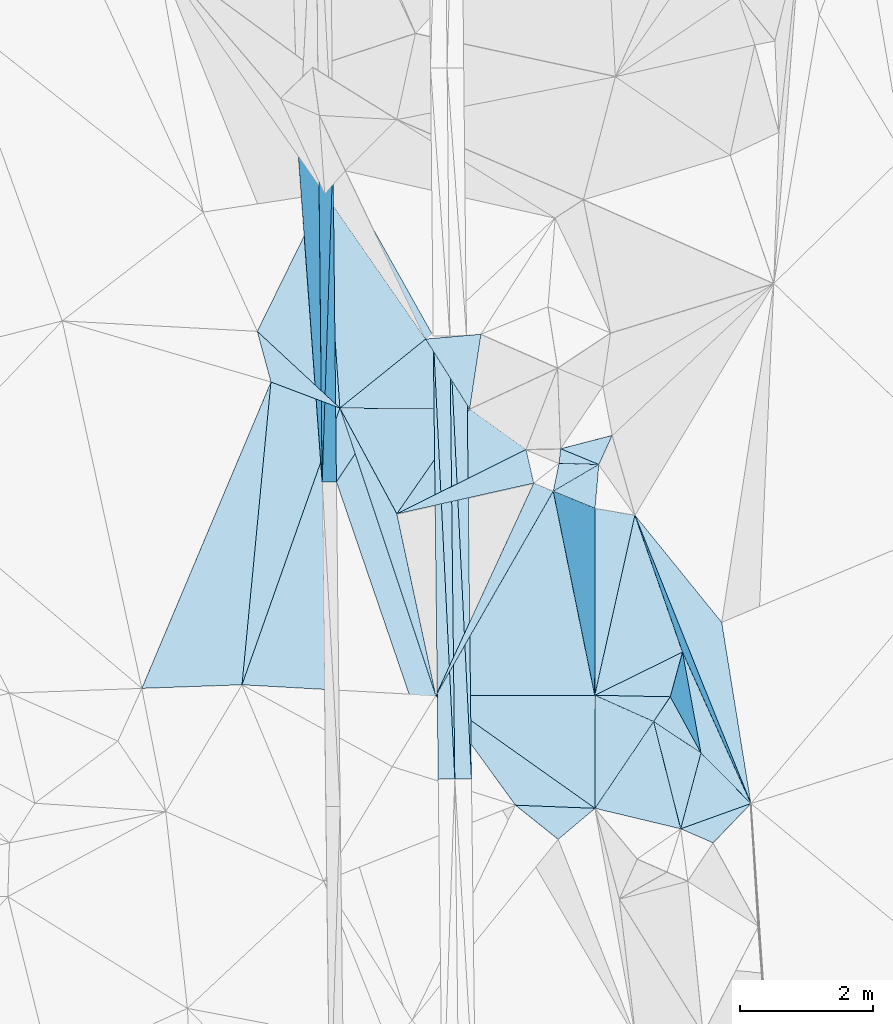
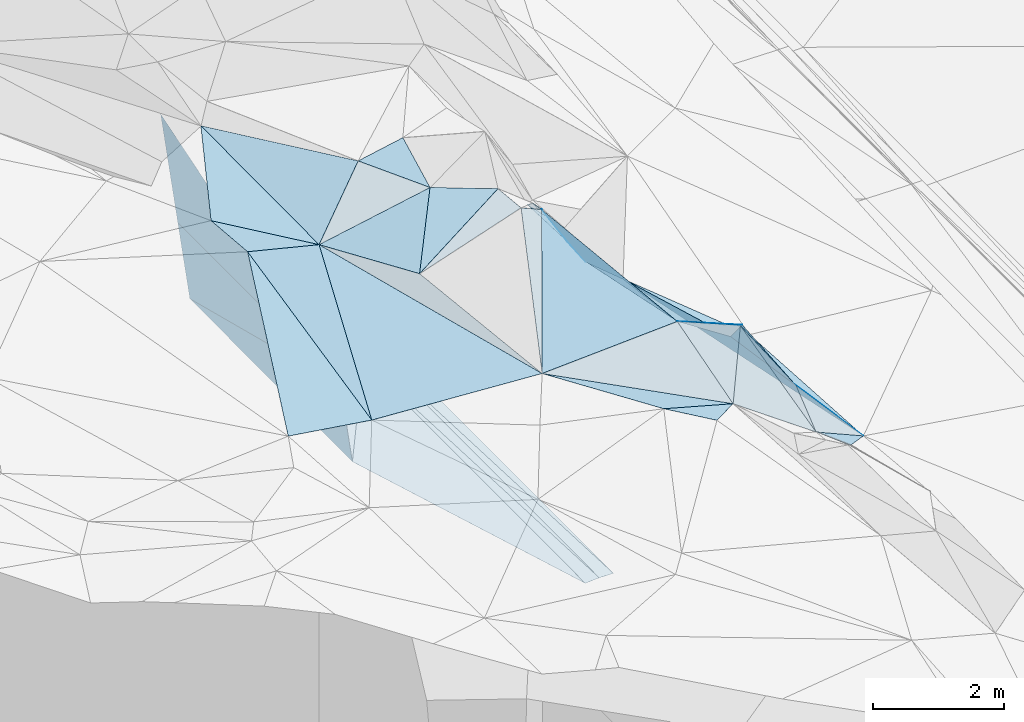
# One storey, part 14 of 275: 45 plates.
"""IFC2X3 building model written with IfcOpenShell, lengths in millimetres."""

from ifc_helpers import new_model, si_unit, frame, origin_with_axes, place, context, subcontext, project, spatial, polyline, outline, extrude, material, type_object, element, save


model = new_model("IFC2X3")

# Units and contexts
model_context = context("Model", 3, precision=1e-05, world=origin_with_axes())
body_context = subcontext(model_context, "Body", "Model", "MODEL_VIEW")
ifc_project = project(units=[si_unit("LENGTHUNIT", "METRE", prefix="MILLI"), si_unit("AREAUNIT", "SQUARE_METRE"), si_unit("VOLUMEUNIT", "CUBIC_METRE"), si_unit("MASSUNIT", "GRAM", prefix="KILO"), si_unit("TIMEUNIT", "SECOND"), si_unit("PLANEANGLEUNIT", "RADIAN"), si_unit("SOLIDANGLEUNIT", "STERADIAN"), si_unit("THERMODYNAMICTEMPERATUREUNIT", "DEGREE_CELSIUS"), si_unit("LUMINOUSINTENSITYUNIT", "LUMEN")], contexts=[model_context])

# Site, building, storey
site_placement = place(None, origin_with_axes())
site = spatial("IfcSite", under=ifc_project, at=site_placement, CompositionType="ELEMENT")
building_placement = place(site_placement, origin_with_axes())
building = spatial("IfcBuilding", under=site, at=building_placement, Name="Undefined", CompositionType="ELEMENT")
storey_placement = place(building_placement, origin_with_axes())
storey = spatial("IfcBuildingStorey", under=building, at=storey_placement, Name="Undefined", CompositionType="ELEMENT", Elevation=0.0)

# Plates
ifc_material = material()
plate_type_1 = type_object("IfcPlateType", PredefinedType="NOTDEFINED")
plate_1_placement = place(storey_placement, frame((-105426.912495277, 16546.9487715069, 43053.8472921868), z_axis=(-0.989920838668954, -0.00755210225404067, -0.141420291756521), x_axis=(0.0319556229056625, 0.960913281916359, -0.274999096001137)))
element("IfcPlate", 1, at=plate_1_placement, inside=storey, type_object=plate_type_1, material=ifc_material, Name="00_PR", context=body_context, shape_type="SweptSolid", body=[
    extrude(outline(polyline([(0.0, 0.0), (5085.87841796875, -9.41508915275335e-09), (421.610626220703, 1455.39086914063), (0.0, 0.0)])), frame((-8.85201319254618e-08, 2.18876761149539e-07, -0.5000001331573), z_axis=(0.0, 0.0, 1.0), x_axis=(1.0, 0.0, 0.0)), (0.0, 0.0, 1.0), 1.0),
])
plate_2_placement = place(storey_placement, frame((-105264.390081203, 21434.0370147272, 41655.2352908371), z_axis=(-0.989920729418167, -0.00755232337685866, -0.14142104468507), x_axis=(-0.0319556228829071, -0.960913281921553, 0.274999095985634)))
element("IfcPlate", 2, at=plate_2_placement, inside=storey, type_object=plate_type_1, material=ifc_material, Name="00_PR", context=body_context, shape_type="SweptSolid", body=[
    extrude(outline(polyline([(0.0, 0.0), (5085.87841796875, -9.41508915275335e-09), (421.443664550781, 1455.43933105469), (0.0, 0.0)])), frame((-8.85201319254618e-08, 2.18876761149539e-07, -0.5000001331573), z_axis=(0.0, 0.0, 1.0), x_axis=(1.0, 0.0, 0.0)), (0.0, 0.0, 1.0), 1.0),
])
plate_type_2 = type_object("IfcPlateType", PredefinedType="NOTDEFINED")
plate_3_placement = place(storey_placement, frame((-103755.768904109, 18743.2154970939, 41598.8007343522), z_axis=(0.0497017362717668, 0.0214177055721637, -0.998534435710455), x_axis=(0.998695835344097, 0.0106236001031736, 0.0499376369805733)))
element("IfcPlate", 3, at=plate_3_placement, inside=storey, type_object=plate_type_2, material=ifc_material, Name="00_PR", context=body_context, shape_type="SweptSolid", body=[
    extrude(outline(polyline([(0.0, 0.0), (250.312210083008, 6.83940015733242e-10), (247.044891357422, 6669.61083984375), (0.0, 0.0)])), frame((-8.85201319254618e-08, 2.18876761149539e-07, -0.5000001331573), z_axis=(0.0, 0.0, 1.0), x_axis=(1.0, 0.0, 0.0)), (0.0, 0.0, 1.0), 1.0),
])
plate_4_placement = place(storey_placement, frame((-103755.768904109, 18743.2154970939, 41598.8007343522), z_axis=(0.0496787260777185, 0.0214166077608199, -0.998535604316298), x_axis=(0.0486362961333859, -0.998635843411922, -0.0189990250114247)))
element("IfcPlate", 4, at=plate_4_placement, inside=storey, type_object=plate_type_2, material=ifc_material, Name="00_PR", context=body_context, shape_type="SweptSolid", body=[
    extrude(outline(polyline([(0.0, 0.0), (6674.1845703125, 1.07684172689915e-08), (6665.19580078125, 250.150833129883), (0.0, 0.0)])), frame((-8.85201319254618e-08, 2.18876761149539e-07, -0.5000001331573), z_axis=(0.0, 0.0, 1.0), x_axis=(1.0, 0.0, 0.0)), (0.0, 0.0, 1.0), 1.0),
])
plate_5_placement = place(storey_placement, frame((-103181.213913095, 12081.0715240582, 41466.9972098134), z_axis=(-0.0202357027179379, 0.0206568841942623, -0.999581817297062), x_axis=(-0.999731085484783, -0.0117437361173947, 0.0199960340423303)))
element("IfcPlate", 5, at=plate_5_placement, inside=storey, type_object=plate_type_2, material=ifc_material, Name="00_PR", context=body_context, shape_type="SweptSolid", body=[
    extrude(outline(polyline([(0.0, 0.0), (250.049530029297, -4.94765117764473e-10), (249.132720947266, 6669.61181640625), (0.0, 0.0)])), frame((-8.85201319254618e-08, 2.18876761149539e-07, -0.5000001331573), z_axis=(0.0, 0.0, 1.0), x_axis=(1.0, 0.0, 0.0)), (0.0, 0.0, 1.0), 1.0),
])
plate_6_placement = place(storey_placement, frame((-103505.818107001, 18745.8743343726, 41611.3002096446), z_axis=(-0.0202125334810141, 0.0206580225063796, -0.999582262545912), x_axis=(0.9997434979277, 0.0106347531180576, -0.0199960090369341)))
element("IfcPlate", 6, at=plate_6_placement, inside=storey, type_object=plate_type_2, material=ifc_material, Name="00_PR", context=body_context, shape_type="SweptSolid", body=[
    extrude(outline(polyline([(0.0, 0.0), (250.049896240234, -1.4915713109076e-09), (256.527893066406, 6669.33154296875), (0.0, 0.0)])), frame((-8.85201319254618e-08, 2.18876761149539e-07, -0.5000001331573), z_axis=(0.0, 0.0, 1.0), x_axis=(1.0, 0.0, 0.0)), (0.0, 0.0, 1.0), 1.0),
])
plate_type_3 = type_object("IfcPlateType", PredefinedType="NOTDEFINED")
plate_7_placement = place(storey_placement, frame((-101839.855637814, 17047.4674480468, 44879.7412121457), z_axis=(-0.804365126994904, -0.291772126949345, -0.51755750251535), x_axis=(0.585574521203103, -0.241977802974004, -0.773659629931426)))
element("IfcPlate", 7, at=plate_7_placement, inside=storey, type_object=plate_type_3, material=ifc_material, Name="00", context=body_context, shape_type="SweptSolid", body=[
    extrude(outline(polyline([(0.0, 0.0), (982.344116210938, 1.28784449771047e-09), (-84.8989639282227, 258.054565429688), (0.0, 0.0)])), frame((-8.85201319254618e-08, 2.18876761149539e-07, -0.5000001331573), z_axis=(0.0, 0.0, 1.0), x_axis=(1.0, 0.0, 0.0)), (0.0, 0.0, 1.0), 1.0),
])
plate_type_4 = type_object("IfcPlateType", PredefinedType="NOTDEFINED")
plate_8_placement = place(storey_placement, frame((-105478.664898104, 21431.8539448154, 43155.2352918256), z_axis=(-0.989920729418167, -0.00755232337685866, -0.14142104468507), x_axis=(0.0105914770758941, -0.999728597747416, -0.020749733958179)))
element("IfcPlate", 8, at=plate_8_placement, inside=storey, type_object=plate_type_4, material=ifc_material, Name="00_PR", context=body_context, shape_type="SweptSolid", body=[
    extrude(outline(polyline([(0.0, 0.0), (4886.2314453125, 6.18456397205591e-10), (-44.4548950195313, 2157.69262695313), (0.0, 0.0)])), frame((-8.85201319254618e-08, 2.18876761149539e-07, -0.5000001331573), z_axis=(0.0, 0.0, 1.0), x_axis=(1.0, 0.0, 0.0)), (0.0, 0.0, 1.0), 1.0),
])
plate_type_5 = type_object("IfcPlateType", PredefinedType="NOTDEFINED")
plate_9_placement = place(storey_placement, frame((-100033.394886136, 11329.9242212821, 43459.6017432081), z_axis=(-0.377068188980827, 0.472665950690349, -0.796496377842804), x_axis=(-0.834528139075674, 0.1996179788847, 0.513532323809202)))
element("IfcPlate", 9, at=plate_9_placement, inside=storey, type_object=plate_type_5, material=ifc_material, Name="00", context=body_context, shape_type="SweptSolid", body=[
    extrude(outline(polyline([(0.0, 0.0), (1544.20654296875, 1.10449036583304e-08), (1252.26123046875, 1588.18823242188), (0.0, 0.0)])), frame((-8.85201319254618e-08, 2.18876761149539e-07, -0.5000001331573), z_axis=(0.0, 0.0, 1.0), x_axis=(1.0, 0.0, 0.0)), (0.0, 0.0, 1.0), 1.0),
])
plate_type_6 = type_object("IfcPlateType", PredefinedType="NOTDEFINED")
plate_10_placement = place(storey_placement, frame((-105212.145265354, 16549.3198246763, 41553.4181093904), z_axis=(-0.000104549365303742, 0.0207505286917967, -0.999784679132683), x_axis=(-0.0105913420959002, 0.999728583859016, 0.020750471991096)))
element("IfcPlate", 10, at=plate_10_placement, inside=storey, type_object=plate_type_6, material=ifc_material, Name="00_PR", context=body_context, shape_type="SweptSolid", body=[
    extrude(outline(polyline([(0.0, 0.0), (4886.0576171875, 6.33008312433958e-09), (2178.81689453125, 1479.51098632813), (0.0, 0.0)])), frame((-8.85201319254618e-08, 2.18876761149539e-07, -0.5000001331573), z_axis=(0.0, 0.0, 1.0), x_axis=(1.0, 0.0, 0.0)), (0.0, 0.0, 1.0), 1.0),
])
plate_type_7 = type_object("IfcPlateType", PredefinedType="NOTDEFINED")
plate_11_placement = place(storey_placement, frame((-105212.145369594, 16549.3198893593, 41553.4181099884), z_axis=(-0.000304582612081838, 0.0208832571060241, -0.999781874611696), x_axis=(0.552975030220593, 0.833019622537564, 0.0172314949992323)))
element("IfcPlate", 11, at=plate_11_placement, inside=storey, type_object=plate_type_7, material=ifc_material, Name="00_PR", context=body_context, shape_type="SweptSolid", body=[
    extrude(outline(polyline([(0.0, 0.0), (2633.66577148438, 1.24855432659388e-08), (-2882.05688476563, 3750.22827148438), (0.0, 0.0)])), frame((-8.85201319254618e-08, 2.18876761149539e-07, -0.5000001331573), z_axis=(0.0, 0.0, 1.0), x_axis=(1.0, 0.0, 0.0)), (0.0, 0.0, 1.0), 1.0),
])
plate_type_8 = type_object("IfcPlateType", PredefinedType="NOTDEFINED")
plate_12_placement = place(storey_placement, frame((-99728.8003509416, 12470.3833376061, 43529.7129676737), z_axis=(-0.814376985429672, 0.0852025865024967, -0.574047598075076), x_axis=(-0.516917806208579, 0.343126606980365, 0.784257682912098)))
element("IfcPlate", 12, at=plate_12_placement, inside=storey, type_object=plate_type_8, material=ifc_material, Name="00", context=body_context, shape_type="SweptSolid", body=[
    extrude(outline(polyline([(0.0, 0.0), (1377.09838867188, 6.54836185276508e-11), (1140.36877441406, 485.756195068359), (0.0, 0.0)])), frame((-8.85201319254618e-08, 2.18876761149539e-07, -0.5000001331573), z_axis=(0.0, 0.0, 1.0), x_axis=(1.0, 0.0, 0.0)), (0.0, 0.0, 1.0), 1.0),
])
plate_type_9 = type_object("IfcPlateType", PredefinedType="NOTDEFINED")
plate_13_placement = place(storey_placement, frame((-103869.859272277, 18697.5813702089, 45399.5203189247), z_axis=(0.194561895567485, 0.204465388672922, -0.95934330332161), x_axis=(0.531126427840644, -0.844209896432618, -0.0722105838119725)))
element("IfcPlate", 13, at=plate_13_placement, inside=storey, type_object=plate_type_9, material=ifc_material, Name="00", context=body_context, shape_type="SweptSolid", body=[
    extrude(outline(polyline([(0.0, 0.0), (1246.35473632813, -1.06228981167078e-09), (226.187622070313, 1710.35437011719), (0.0, 0.0)])), frame((-8.85201319254618e-08, 2.18876761149539e-07, -0.5000001331573), z_axis=(0.0, 0.0, 1.0), x_axis=(1.0, 0.0, 0.0)), (0.0, 0.0, 1.0), 1.0),
])
plate_14_placement = place(storey_placement, frame((-106197.375553037, 18051.2344874081, 44909.5007154938), z_axis=(0.0249032270764645, 0.0480394857178102, -0.998534945354015), x_axis=(0.935354299009453, -0.353655877299177, 0.00631314313833182)))
element("IfcPlate", 14, at=plate_14_placement, inside=storey, type_object=plate_type_9, material=ifc_material, Name="00", context=body_context, shape_type="SweptSolid", body=[
    extrude(outline(polyline([(0.0, 0.0), (1108.79797363281, -4.98403096571565e-09), (1202.21179199219, 4421.00537109375), (0.0, 0.0)])), frame((-8.85201319254618e-08, 2.18876761149539e-07, -0.5000001331573), z_axis=(0.0, 0.0, 1.0), x_axis=(1.0, 0.0, 0.0)), (0.0, 0.0, 1.0), 1.0),
])
plate_type_10 = type_object("IfcPlateType", PredefinedType="NOTDEFINED")
plate_15_placement = place(storey_placement, frame((-103207.932088423, 17645.3692844254, 45309.508465328), z_axis=(0.105104380772347, 0.150211941170283, -0.983051088129359), x_axis=(-0.531126427840561, 0.844209896432885, 0.0722105838094505)))
element("IfcPlate", 15, at=plate_15_placement, inside=storey, type_object=plate_type_10, material=ifc_material, Name="00", context=body_context, shape_type="SweptSolid", body=[
    extrude(outline(polyline([(0.0, 0.0), (1246.35473632813, -1.06228981167078e-09), (873.025939941406, 753.409362792969), (0.0, 0.0)])), frame((-8.85201319254618e-08, 2.18876761149539e-07, -0.5000001331573), z_axis=(0.0, 0.0, 1.0), x_axis=(1.0, 0.0, 0.0)), (0.0, 0.0, 1.0), 1.0),
])
plate_type_11 = type_object("IfcPlateType", PredefinedType="NOTDEFINED")
plate_16_placement = place(storey_placement, frame((-101321.864192584, 11638.0820197054, 44252.5214922899), z_axis=(0.0522033399121631, 0.285423625424812, -0.956978665045032), x_axis=(-0.809619555521164, 0.573102611661805, 0.126765814887656)))
element("IfcPlate", 16, at=plate_16_placement, inside=storey, type_object=plate_type_11, material=ifc_material, Name="00", context=body_context, shape_type="SweptSolid", body=[
    extrude(outline(polyline([(0.0, 0.0), (2958.21069335938, -1.6858393792063e-08), (1042.1123046875, 1436.36901855469), (0.0, 0.0)])), frame((-8.85201319254618e-08, 2.18876761149539e-07, -0.5000001331573), z_axis=(0.0, 0.0, 1.0), x_axis=(1.0, 0.0, 0.0)), (0.0, 0.0, 1.0), 1.0),
])
plate_type_12 = type_object("IfcPlateType", PredefinedType="NOTDEFINED")
plate_17_placement = place(storey_placement, frame((-102519.218428604, 11684.7978239865, 44549.5195154742), z_axis=(-0.243540445866545, -0.131497164188357, -0.960935246016892), x_axis=(-0.587406914221267, 0.808387271173938, 0.0382509729157705)))
element("IfcPlate", 17, at=plate_17_placement, inside=storey, type_object=plate_type_12, material=ifc_material, Name="00", context=body_context, shape_type="SweptSolid", body=[
    extrude(outline(polyline([(0.0, 0.0), (2039.16381835938, 6.98491930961609e-10), (-752.540832519531, 978.46630859375), (0.0, 0.0)])), frame((-8.85201319254618e-08, 2.18876761149539e-07, -0.5000001331573), z_axis=(0.0, 0.0, 1.0), x_axis=(1.0, 0.0, 0.0)), (0.0, 0.0, 1.0), 1.0),
])
plate_type_13 = type_object("IfcPlateType", PredefinedType="NOTDEFINED")
plate_18_placement = place(storey_placement, frame((-99728.6817091891, 12470.4421185406, 43529.6044388853), z_axis=(-0.57709569134781, 0.202764348347549, -0.791105038580205), x_axis=(0.577309642236302, -0.583879469989431, -0.570787474902746)))
element("IfcPlate", 18, at=plate_18_placement, inside=storey, type_object=plate_type_13, material=ifc_material, Name="00", context=body_context, shape_type="SweptSolid", body=[
    extrude(outline(polyline([(0.0, 0.0), (1301.71044921875, -2.91038304567337e-10), (529.9873046875, 1057.36157226563), (0.0, 0.0)])), frame((-8.85201319254618e-08, 2.18876761149539e-07, -0.5000001331573), z_axis=(0.0, 0.0, 1.0), x_axis=(1.0, 0.0, 0.0)), (0.0, 0.0, 1.0), 1.0),
])
plate_type_14 = type_object("IfcPlateType", PredefinedType="NOTDEFINED")
plate_19_placement = place(storey_placement, frame((-100440.619342959, 12942.9798218094, 44609.6973617992), z_axis=(-0.758997428753563, 0.239968310642129, -0.605258715784451), x_axis=(0.516917806207445, -0.343126606984507, -0.784257682911033)))
element("IfcPlate", 19, at=plate_19_placement, inside=storey, type_object=plate_type_14, material=ifc_material, Name="00", context=body_context, shape_type="SweptSolid", body=[
    extrude(outline(polyline([(0.0, 0.0), (1377.09838867188, 6.54836185276508e-11), (1665.82141113281, 1146.96948242188), (0.0, 0.0)])), frame((-8.85201319254618e-08, 2.18876761149539e-07, -0.5000001331573), z_axis=(0.0, 0.0, 1.0), x_axis=(1.0, 0.0, 0.0)), (0.0, 0.0, 1.0), 1.0),
])
plate_type_15 = type_object("IfcPlateType", PredefinedType="NOTDEFINED")
plate_20_placement = place(storey_placement, frame((-101322.011540896, 11637.910142957, 44252.5157878899), z_axis=(-0.242522260697239, -0.0583322354853152, -0.968390573771547), x_axis=(-0.745290123900326, -0.627819460733854, 0.22446682592421)))
element("IfcPlate", 20, at=plate_20_placement, inside=storey, type_object=plate_type_15, material=ifc_material, Name="00", context=body_context, shape_type="SweptSolid", body=[
    extrude(outline(polyline([(0.0, 0.0), (743.985229492188, -1.10594555735588e-09), (929.472778320313, 812.277282714844), (0.0, 0.0)])), frame((-8.85201319254618e-08, 2.18876761149539e-07, -0.5000001331573), z_axis=(0.0, 0.0, 1.0), x_axis=(1.0, 0.0, 0.0)), (0.0, 0.0, 1.0), 1.0),
])
plate_type_16 = type_object("IfcPlateType", PredefinedType="NOTDEFINED")
plate_21_placement = place(storey_placement, frame((-102359.300111867, 17036.544396977, 45359.510157467), z_axis=(0.0669992438558387, 0.189113262306354, -0.97966692061261), x_axis=(0.217566101141657, -0.961014696793674, -0.170633361862742)))
element("IfcPlate", 21, at=plate_21_placement, inside=storey, type_object=plate_type_16, material=ifc_material, Name="00", context=body_context, shape_type="SweptSolid", body=[
    extrude(outline(polyline([(0.0, 0.0), (527.446655273438, 3.62342689186335e-09), (562.7109375, 2122.41748046875), (0.0, 0.0)])), frame((-8.85201319254618e-08, 2.18876761149539e-07, -0.5000001331573), z_axis=(0.0, 0.0, 1.0), x_axis=(1.0, 0.0, 0.0)), (0.0, 0.0, 1.0), 1.0),
])
plate_type_17 = type_object("IfcPlateType", PredefinedType="NOTDEFINED")
plate_22_placement = place(storey_placement, frame((-101950.785368783, 16408.1385696121, 45209.7278007745), z_axis=(-0.837564346177722, -0.0464462281284567, -0.544360830611944), x_axis=(0.188395252441647, 0.910712558556422, -0.367572937721297)))
element("IfcPlate", 22, at=plate_22_placement, inside=storey, type_object=plate_type_17, material=ifc_material, Name="00", context=body_context, shape_type="SweptSolid", body=[
    extrude(outline(polyline([(0.0, 0.0), (462.493255615234, -3.05590219795704e-10), (895.796875, 1008.88452148438), (0.0, 0.0)])), frame((-8.85201319254618e-08, 2.18876761149539e-07, -0.5000001331573), z_axis=(0.0, 0.0, 1.0), x_axis=(1.0, 0.0, 0.0)), (0.0, 0.0, 1.0), 1.0),
])
plate_type_18 = type_object("IfcPlateType", PredefinedType="NOTDEFINED")
plate_23_placement = place(storey_placement, frame((-101264.586775403, 16810.0256580471, 44119.6838422254), z_axis=(-0.738032833137247, 0.23559978571144, -0.63229761836032), x_axis=(-0.585574521205509, 0.241977802974297, 0.773659629929514)))
element("IfcPlate", 23, at=plate_23_placement, inside=storey, type_object=plate_type_18, material=ifc_material, Name="00", context=body_context, shape_type="SweptSolid", body=[
    extrude(outline(polyline([(0.0, 0.0), (982.344116210938, 1.28784449771047e-09), (-65.1502838134766, 482.343688964844), (0.0, 0.0)])), frame((-8.85201319254618e-08, 2.18876761149539e-07, -0.5000001331573), z_axis=(0.0, 0.0, 1.0), x_axis=(1.0, 0.0, 0.0)), (0.0, 0.0, 1.0), 1.0),
])
plate_type_19 = type_object("IfcPlateType", PredefinedType="NOTDEFINED")
plate_24_placement = place(storey_placement, frame((-101325.879227179, 13338.6963826618, 44759.5211087527), z_axis=(-0.0346783345820825, 0.285455000982104, -0.957764509430643), x_axis=(0.902287823128402, -0.403140048881448, -0.152822724822175)))
element("IfcPlate", 24, at=plate_24_placement, inside=storey, type_object=plate_type_19, material=ifc_material, Name="00", context=body_context, shape_type="SweptSolid", body=[
    extrude(outline(polyline([(0.0, 0.0), (981.529418945313, -8.03993316367269e-10), (766.650451660156, 1600.43774414063), (0.0, 0.0)])), frame((-8.85201319254618e-08, 2.18876761149539e-07, -0.5000001331573), z_axis=(0.0, 0.0, 1.0), x_axis=(1.0, 0.0, 0.0)), (0.0, 0.0, 1.0), 1.0),
])
plate_type_20 = type_object("IfcPlateType", PredefinedType="NOTDEFINED")
plate_25_placement = place(storey_placement, frame((-100722.346658374, 16047.9923126619, 43701.8551199008), z_axis=(-0.907553844649081, -0.303966058626844, -0.289742392938166), x_axis=(0.366259058131067, -0.910478286836121, -0.192051012850509)))
element("IfcPlate", 25, at=plate_25_placement, inside=storey, type_object=plate_type_20, material=ifc_material, Name="00", context=body_context, shape_type="SweptSolid", body=[
    extrude(outline(polyline([(0.0, 0.0), (4764.359375, 1.01863406598568e-09), (2153.96362304688, 353.730072021484), (0.0, 0.0)])), frame((-8.85201319254618e-08, 2.18876761149539e-07, -0.5000001331573), z_axis=(0.0, 0.0, 1.0), x_axis=(1.0, 0.0, 0.0)), (0.0, 0.0, 1.0), 1.0),
])
plate_type_21 = type_object("IfcPlateType", PredefinedType="NOTDEFINED")
plate_26_placement = place(storey_placement, frame((-98977.0359099176, 11710.3466047302, 42786.5202725437), z_axis=(-0.265260585122329, 0.0956675973271701, -0.959418851598303), x_axis=(-0.366259058503839, 0.910478286670322, 0.192051012925621)))
element("IfcPlate", 26, at=plate_26_placement, inside=storey, type_object=plate_type_21, material=ifc_material, Name="00", context=body_context, shape_type="SweptSolid", body=[
    extrude(outline(polyline([(0.0, 0.0), (4764.359375, 1.01863406598568e-09), (2716.51049804688, 623.362060546875), (0.0, 0.0)])), frame((-8.85201319254618e-08, 2.18876761149539e-07, -0.5000001331573), z_axis=(0.0, 0.0, 1.0), x_axis=(1.0, 0.0, 0.0)), (0.0, 0.0, 1.0), 1.0),
])
plate_type_22 = type_object("IfcPlateType", PredefinedType="NOTDEFINED")
plate_27_placement = place(storey_placement, frame((-100189.900583667, 13315.7954362556, 44309.5843737047), z_axis=(-0.337992299207884, -0.441371931332272, -0.83123523981373), x_axis=(-0.463586329890127, -0.690556685891821, 0.555174907852568)))
element("IfcPlate", 27, at=plate_27_placement, inside=storey, type_object=plate_type_22, material=ifc_material, Name="00", context=body_context, shape_type="SweptSolid", body=[
    extrude(outline(polyline([(0.0, 0.0), (540.370239257813, -5.38420863449574e-10), (760.959716796875, 956.420532226563), (0.0, 0.0)])), frame((-8.85201319254618e-08, 2.18876761149539e-07, -0.5000001331573), z_axis=(0.0, 0.0, 1.0), x_axis=(1.0, 0.0, 0.0)), (0.0, 0.0, 1.0), 1.0),
])
plate_type_23 = type_object("IfcPlateType", PredefinedType="NOTDEFINED")
plate_28_placement = place(storey_placement, frame((-103716.635990753, 13333.4173898559, 44627.6030919125), z_axis=(0.559015658193211, 0.239555573148716, -0.793797594647528), x_axis=(-0.315875660998104, 0.946690212463389, 0.0632472008474262)))
element("IfcPlate", 28, at=plate_28_placement, inside=storey, type_object=plate_type_23, material=ifc_material, Name="00", context=body_context, shape_type="SweptSolid", body=[
    extrude(outline(polyline([(0.0, 0.0), (4569.3720703125, 1.56433088704944e-09), (2799.87890625, 388.3642578125), (0.0, 0.0)])), frame((-8.85201319254618e-08, 2.18876761149539e-07, -0.5000001331573), z_axis=(0.0, 0.0, 1.0), x_axis=(1.0, 0.0, 0.0)), (0.0, 0.0, 1.0), 1.0),
])
plate_type_24 = type_object("IfcPlateType", PredefinedType="NOTDEFINED")
plate_29_placement = place(storey_placement, frame((-105160.215167796, 17659.2114530251, 44916.5212711383), z_axis=(0.107728031170135, 0.267829617075333, -0.957424653702571), x_axis=(-0.935354299010364, 0.35365587729671, -0.00631314314156684)))
element("IfcPlate", 29, at=plate_29_placement, inside=storey, type_object=plate_type_24, material=ifc_material, Name="00", context=body_context, shape_type="SweptSolid", body=[
    extrude(outline(polyline([(0.0, 0.0), (1108.79797363281, -4.98403096571565e-09), (1569.39587402344, 668.393310546875), (0.0, 0.0)])), frame((-8.85201319254618e-08, 2.18876761149539e-07, -0.5000001331573), z_axis=(0.0, 0.0, 1.0), x_axis=(1.0, 0.0, 0.0)), (0.0, 0.0, 1.0), 1.0),
])
plate_type_25 = type_object("IfcPlateType", PredefinedType="NOTDEFINED")
plate_30_placement = place(storey_placement, frame((-102244.628220487, 16529.6854711211, 45269.5170083895), z_axis=(-0.0982552316223304, 0.239283603546341, -0.965965458250304), x_axis=(0.908392473051043, -0.374839587851974, -0.185252255811292)))
element("IfcPlate", 30, at=plate_30_placement, inside=storey, type_object=plate_type_25, material=ifc_material, Name="00", context=body_context, shape_type="SweptSolid", body=[
    extrude(outline(polyline([(0.0, 0.0), (323.882690429688, -1.08047970570624e-09), (-20.4394989013672, 3577.10107421875), (0.0, 0.0)])), frame((-8.85201319254618e-08, 2.18876761149539e-07, -0.5000001331573), z_axis=(0.0, 0.0, 1.0), x_axis=(1.0, 0.0, 0.0)), (0.0, 0.0, 1.0), 1.0),
])
plate_type_26 = type_object("IfcPlateType", PredefinedType="NOTDEFINED")
plate_31_placement = place(storey_placement, frame((-98977.1658610341, 11710.2764944264, 42786.5751292415), z_axis=(-0.525344601618066, -0.0445112185972618, -0.849724544172841), x_axis=(-0.62835568194737, -0.653069813048629, 0.422692507916908)))
element("IfcPlate", 31, at=plate_31_placement, inside=storey, type_object=plate_type_26, material=ifc_material, Name="00", context=body_context, shape_type="SweptSolid", body=[
    extrude(outline(polyline([(0.0, 0.0), (906.096008300781, 2.2846506908536e-09), (1196.77160644531, 530.384460449219), (0.0, 0.0)])), frame((-8.85201319254618e-08, 2.18876761149539e-07, -0.5000001331573), z_axis=(0.0, 0.0, 1.0), x_axis=(1.0, 0.0, 0.0)), (0.0, 0.0, 1.0), 1.0),
])
plate_type_27 = type_object("IfcPlateType", PredefinedType="NOTDEFINED")
plate_32_placement = place(storey_placement, frame((-103207.924668794, 17645.3371607447, 45309.5054648952), z_axis=(0.119945678963274, 0.0859652324074595, -0.989051572424396), x_axis=(0.811595458971185, -0.582259705785456, 0.0478167961702301)))
element("IfcPlate", 32, at=plate_32_placement, inside=storey, type_object=plate_type_27, material=ifc_material, Name="00", context=body_context, shape_type="SweptSolid", body=[
    extrude(outline(polyline([(0.0, 0.0), (1045.65771484375, 1.84809323400259e-09), (16.5446109771729, 1939.64587402344), (0.0, 0.0)])), frame((-8.85201319254618e-08, 2.18876761149539e-07, -0.5000001331573), z_axis=(0.0, 0.0, 1.0), x_axis=(1.0, 0.0, 0.0)), (0.0, 0.0, 1.0), 1.0),
])
plate_type_28 = type_object("IfcPlateType", PredefinedType="NOTDEFINED")
plate_33_placement = place(storey_placement, frame((-101264.643551251, 16809.9255693561, 44119.7384842581), z_axis=(-0.851587696538333, 0.0354216196405588, -0.523014057140509), x_axis=(-0.0875427408195709, -0.993313237620099, 0.0752667290273306)))
element("IfcPlate", 33, at=plate_33_placement, inside=storey, type_object=plate_type_28, material=ifc_material, Name="00", context=body_context, shape_type="SweptSolid", body=[
    extrude(outline(polyline([(0.0, 0.0), (664.304138183594, 1.00408215075731e-09), (541.167785644531, 1235.89538574219), (0.0, 0.0)])), frame((-8.85201319254618e-08, 2.18876761149539e-07, -0.5000001331573), z_axis=(0.0, 0.0, 1.0), x_axis=(1.0, 0.0, 0.0)), (0.0, 0.0, 1.0), 1.0),
])
plate_type_29 = type_object("IfcPlateType", PredefinedType="NOTDEFINED")
plate_34_placement = place(storey_placement, frame((-105160.138309621, 17659.1379131097, 44916.5211522526), z_axis=(0.261280021539059, 0.12078629294883, -0.957676052629608), x_axis=(-0.0696010141527821, 0.991914904655596, 0.106115600884057)))
element("IfcPlate", 34, at=plate_34_placement, inside=storey, type_object=plate_type_29, material=ifc_material, Name="00", context=body_context, shape_type="SweptSolid", body=[
    extrude(outline(polyline([(0.0, 0.0), (3251.17138671875, -9.31322574615479e-10), (991.452819824219, 1411.91162109375), (0.0, 0.0)])), frame((-8.85201319254618e-08, 2.18876761149539e-07, -0.5000001331573), z_axis=(0.0, 0.0, 1.0), x_axis=(1.0, 0.0, 0.0)), (0.0, 0.0, 1.0), 1.0),
])
plate_type_30 = type_object("IfcPlateType", PredefinedType="NOTDEFINED")
plate_35_placement = place(storey_placement, frame((-104303.498058842, 16067.5788017521, 45039.5100729989), z_axis=(0.197459072991629, 0.0305608550533241, -0.979834653720563), x_axis=(-0.472878751091411, 0.878507770850116, -0.0678953851317375)))
element("IfcPlate", 35, at=plate_35_placement, inside=storey, type_object=plate_type_30, material=ifc_material, Name="00", context=body_context, shape_type="SweptSolid", body=[
    extrude(outline(polyline([(0.0, 0.0), (1811.61059570313, -3.31783667206764e-09), (849.625183105469, 1743.74230957031), (0.0, 0.0)])), frame((-8.85201319254618e-08, 2.18876761149539e-07, -0.5000001331573), z_axis=(0.0, 0.0, 1.0), x_axis=(1.0, 0.0, 0.0)), (0.0, 0.0, 1.0), 1.0),
])
plate_type_31 = type_object("IfcPlateType", PredefinedType="NOTDEFINED")
plate_36_placement = place(storey_placement, frame((-101322.684542419, 16149.9658447316, 44169.6173560411), z_axis=(-0.623554567702208, -0.15982021388289, -0.765269364558741), x_axis=(0.781768823897693, -0.132666198875976, -0.609292364680059)))
element("IfcPlate", 36, at=plate_36_placement, inside=storey, type_object=plate_type_31, material=ifc_material, Name="00", context=body_context, shape_type="SweptSolid", body=[
    extrude(outline(polyline([(0.0, 0.0), (768.104187011719, -2.24827090278268e-09), (10.7797880172729, 2872.71362304688), (0.0, 0.0)])), frame((-8.85201319254618e-08, 2.18876761149539e-07, -0.5000001331573), z_axis=(0.0, 0.0, 1.0), x_axis=(1.0, 0.0, 0.0)), (0.0, 0.0, 1.0), 1.0),
])
plate_type_32 = type_object("IfcPlateType", PredefinedType="NOTDEFINED")
plate_37_placement = place(storey_placement, frame((-101950.797787187, 16408.1103349528, 45209.7523239049), z_axis=(-0.862589768747944, -0.102876718361168, -0.495333495405475), x_axis=(0.505625120345983, -0.20782045604584, -0.83734932717714)))
element("IfcPlate", 37, at=plate_37_placement, inside=storey, type_object=plate_type_32, material=ifc_material, Name="00", context=body_context, shape_type="SweptSolid", body=[
    extrude(outline(polyline([(0.0, 0.0), (1242.01452636719, -3.14685166813433e-10), (1330.49975585938, 2871.37084960938), (0.0, 0.0)])), frame((-8.85201319254618e-08, 2.18876761149539e-07, -0.5000001331573), z_axis=(0.0, 0.0, 1.0), x_axis=(1.0, 0.0, 0.0)), (0.0, 0.0, 1.0), 1.0),
])
plate_type_33 = type_object("IfcPlateType", PredefinedType="NOTDEFINED")
plate_38_placement = place(storey_placement, frame((-100006.023949725, 13987.7663114308, 43619.6717261298), z_axis=(-0.747943251111524, -0.0977180448977313, -0.656530331986337), x_axis=(0.390526918202075, -0.864577636978325, -0.316218651879624)))
element("IfcPlate", 38, at=plate_38_placement, inside=storey, type_object=plate_type_33, material=ifc_material, Name="00", context=body_context, shape_type="SweptSolid", body=[
    extrude(outline(polyline([(0.0, 0.0), (2634.25317382813, -1.19325704872608e-09), (1448.71044921875, 537.529724121094), (0.0, 0.0)])), frame((-8.85201319254618e-08, 2.18876761149539e-07, -0.5000001331573), z_axis=(0.0, 0.0, 1.0), x_axis=(1.0, 0.0, 0.0)), (0.0, 0.0, 1.0), 1.0),
])
plate_type_34 = type_object("IfcPlateType", PredefinedType="NOTDEFINED")
plate_39_placement = place(storey_placement, frame((-101326.158308912, 13338.466252321, 44759.6069324546), z_axis=(-0.592843084359044, -0.174806080993942, -0.786116983263429), x_axis=(0.203297528944269, 0.912055216134701, -0.356125536077712)))
element("IfcPlate", 39, at=plate_39_placement, inside=storey, type_object=plate_type_34, material=ifc_material, Name="00", context=body_context, shape_type="SweptSolid", body=[
    extrude(outline(polyline([(0.0, 0.0), (2970.86254882813, 5.82076609134674e-09), (1266.54125976563, 1363.80834960938), (0.0, 0.0)])), frame((-8.85201319254618e-08, 2.18876761149539e-07, -0.5000001331573), z_axis=(0.0, 0.0, 1.0), x_axis=(1.0, 0.0, 0.0)), (0.0, 0.0, 1.0), 1.0),
])
plate_type_35 = type_object("IfcPlateType", PredefinedType="NOTDEFINED")
plate_40_placement = place(storey_placement, frame((-100005.796193328, 13987.4926669429, 43619.6469864125), z_axis=(-0.292432225060209, -0.645007036352329, -0.706009431100124), x_axis=(-0.187750425923373, -0.68518825966072, 0.70375196368373)))
element("IfcPlate", 40, at=plate_40_placement, inside=storey, type_object=plate_type_35, material=ifc_material, Name="00", context=body_context, shape_type="SweptSolid", body=[
    extrude(outline(polyline([(0.0, 0.0), (980.459106445313, 2.6775524020195e-09), (1495.01391601563, 1108.61767578125), (0.0, 0.0)])), frame((-8.85201319254618e-08, 2.18876761149539e-07, -0.5000001331573), z_axis=(0.0, 0.0, 1.0), x_axis=(1.0, 0.0, 0.0)), (0.0, 0.0, 1.0), 1.0),
])
plate_type_36 = type_object("IfcPlateType", PredefinedType="NOTDEFINED")
plate_41_placement = place(storey_placement, frame((-99728.8492873516, 12470.2687706416, 43529.8082364778), z_axis=(-0.912252115332539, -0.143931405237192, -0.383509880782432), x_axis=(-0.372192381297521, 0.68226256212441, 0.629277862019248)))
element("IfcPlate", 41, at=plate_41_placement, inside=storey, type_object=plate_type_36, material=ifc_material, Name="00", context=body_context, shape_type="SweptSolid", body=[
    extrude(outline(polyline([(0.0, 0.0), (1239.51599121094, -2.40834197029471e-09), (1195.14392089844, 979.454467773438), (0.0, 0.0)])), frame((-8.85201319254618e-08, 2.18876761149539e-07, -0.5000001331573), z_axis=(0.0, 0.0, 1.0), x_axis=(1.0, 0.0, 0.0)), (0.0, 0.0, 1.0), 1.0),
])
plate_type_37 = type_object("IfcPlateType", PredefinedType="NOTDEFINED")
plate_42_placement = place(storey_placement, frame((-106632.86306677, 13496.2312790524, 44679.5085390166), z_axis=(-0.17195220050628, 0.0660657349192881, -0.98288746019604), x_axis=(-0.984827378104848, -0.0352271706595627, 0.169923752849483)))
element("IfcPlate", 42, at=plate_42_placement, inside=storey, type_object=plate_type_37, material=ifc_material, Name="00", context=body_context, shape_type="SweptSolid", body=[
    extrude(outline(polyline([(0.0, 0.0), (1530.09802246094, -8.32733348943293e-09), (-550.160827636719, 4548.39794921875), (0.0, 0.0)])), frame((-8.85201319254618e-08, 2.18876761149539e-07, -0.5000001331573), z_axis=(0.0, 0.0, 1.0), x_axis=(1.0, 0.0, 0.0)), (0.0, 0.0, 1.0), 1.0),
])
plate_type_38 = type_object("IfcPlateType", PredefinedType="NOTDEFINED")
plate_43_placement = place(storey_placement, frame((-106403.048607867, 18813.1766348781, 45099.503278825), z_axis=(-0.0509107182686799, 0.102703051954908, -0.993408366123678), x_axis=(0.439547479306811, 0.895483442110242, 0.0700529681128598)))
element("IfcPlate", 43, at=plate_43_placement, inside=storey, type_object=plate_type_38, material=ifc_material, Name="00", context=body_context, shape_type="SweptSolid", body=[
    extrude(outline(polyline([(0.0, 0.0), (2312.53588867188, -2.56113708019257e-09), (-500.000885009766, 1630.87463378906), (0.0, 0.0)])), frame((-8.85201319254618e-08, 2.18876761149539e-07, -0.5000001331573), z_axis=(0.0, 0.0, 1.0), x_axis=(1.0, 0.0, 0.0)), (0.0, 0.0, 1.0), 1.0),
])
plate_type_39 = type_object("IfcPlateType", PredefinedType="NOTDEFINED")
plate_44_placement = place(storey_placement, frame((-105160.276213926, 17659.1084820673, 44916.5009906045), z_axis=(-0.0143399077523025, 0.0618891098325084, -0.997980012389925), x_axis=(0.31587566138275, -0.946690212329137, -0.0632472009358872)))
element("IfcPlate", 44, at=plate_44_placement, inside=storey, type_object=plate_type_39, material=ifc_material, Name="00", context=body_context, shape_type="SweptSolid", body=[
    extrude(outline(polyline([(0.0, 0.0), (4569.3720703125, 1.56433088704944e-09), (3490.81713867188, 2714.4443359375), (0.0, 0.0)])), frame((-8.85201319254618e-08, 2.18876761149539e-07, -0.5000001331573), z_axis=(0.0, 0.0, 1.0), x_axis=(1.0, 0.0, 0.0)), (0.0, 0.0, 1.0), 1.0),
])
plate_type_40 = type_object("IfcPlateType", PredefinedType="NOTDEFINED")
plate_45_placement = place(storey_placement, frame((-101325.834923724, 13338.6314770165, 44759.506812996), z_axis=(0.0541094314514092, 0.155603898921935, -0.98633645175888), x_axis=(-0.998477229684774, -0.00219486556400039, -0.0551217231785733)))
element("IfcPlate", 45, at=plate_45_placement, inside=storey, type_object=plate_type_40, material=ifc_material, Name="00", context=body_context, shape_type="SweptSolid", body=[
    extrude(outline(polyline([(0.0, 0.0), (2394.7001953125, -1.49811967276037e-08), (592.011474609375, 3108.78149414063), (0.0, 0.0)])), frame((-8.85201319254618e-08, 2.18876761149539e-07, -0.5000001331573), z_axis=(0.0, 0.0, 1.0), x_axis=(1.0, 0.0, 0.0)), (0.0, 0.0, 1.0), 1.0),
])

save(model, "model.ifc")
